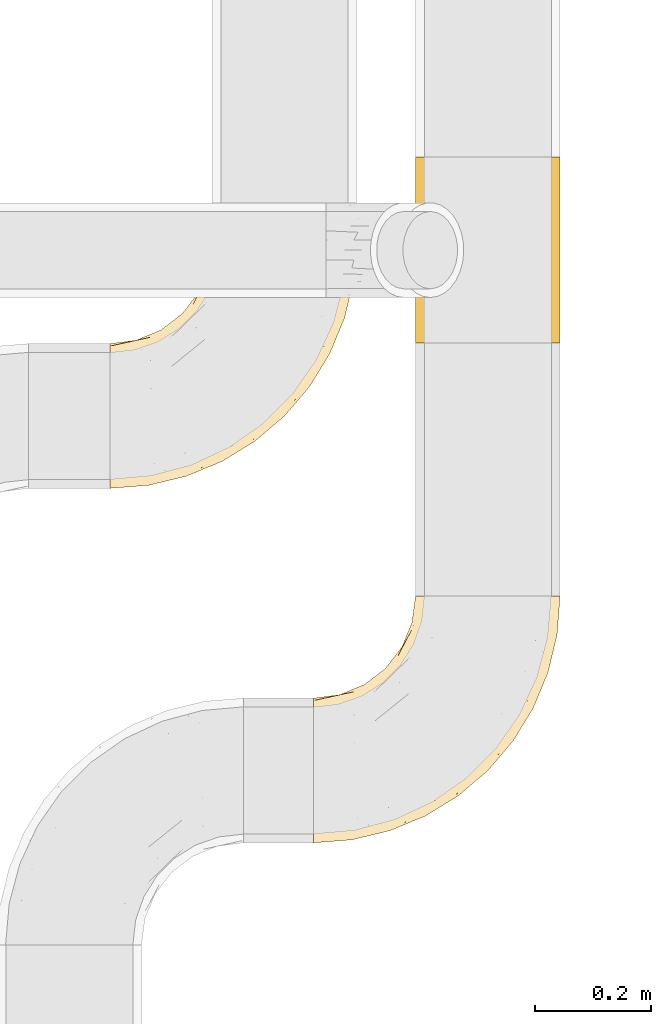
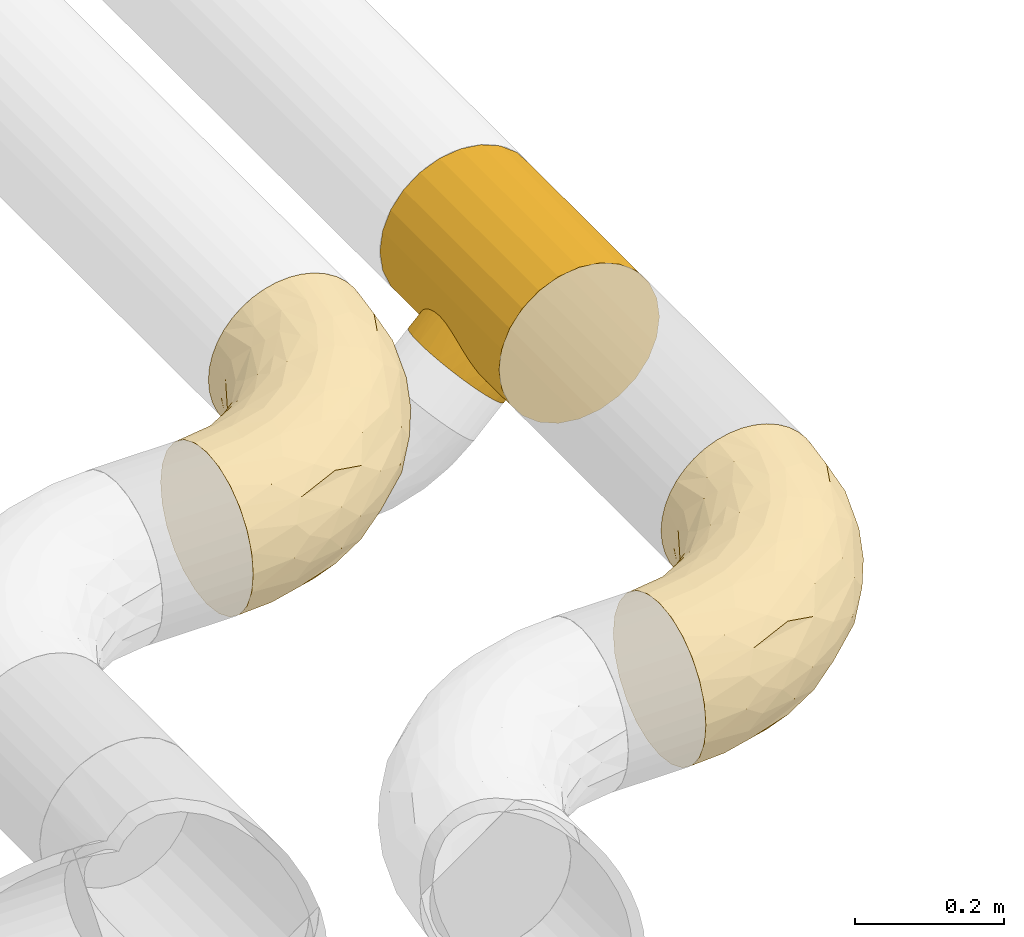
# One storey, part 39 of 93: 3 coverings.
"""IFC2X3 building model written with IfcOpenShell, lengths in millimetres."""

from ifc_helpers import new_model, entity, si_unit, converted_unit, derived_unit, direction, frame, origin, place, context, subcontext, project, spatial, faceted_brep, element, save


model = new_model("IFC2X3")

# Units and contexts
model_context = context("Model", 3, precision=0.01, world=origin(), true_north=direction((6.12303176911189e-17, 1.0)))
body_context = subcontext(model_context, "Body", "Model", "MODEL_VIEW")
ifc_project = project(units=[si_unit("LENGTHUNIT", "METRE", prefix="MILLI"), si_unit("AREAUNIT", "SQUARE_METRE"), si_unit("VOLUMEUNIT", "CUBIC_METRE"), converted_unit("PLANEANGLEUNIT", "DEGREE", entity("IfcRatioMeasure", 0.0174532925199433), si_unit("PLANEANGLEUNIT", "RADIAN"), dimensions=[0, 0, 0, 0, 0, 0, 0]), si_unit("MASSUNIT", "GRAM", prefix="KILO"), derived_unit("MASSDENSITYUNIT", [(si_unit("MASSUNIT", "GRAM", prefix="KILO"), 1), (si_unit("LENGTHUNIT", "METRE"), -3)]), derived_unit("MOMENTOFINERTIAUNIT", [(si_unit("LENGTHUNIT", "METRE"), 4)]), si_unit("TIMEUNIT", "SECOND"), si_unit("FREQUENCYUNIT", "HERTZ"), si_unit("THERMODYNAMICTEMPERATUREUNIT", "DEGREE_CELSIUS"), derived_unit("THERMALTRANSMITTANCEUNIT", [(si_unit("MASSUNIT", "GRAM", prefix="KILO"), 1), (si_unit("THERMODYNAMICTEMPERATUREUNIT", "KELVIN"), -1), (si_unit("TIMEUNIT", "SECOND"), -3)]), derived_unit("VOLUMETRICFLOWRATEUNIT", [(si_unit("LENGTHUNIT", "METRE"), 3), (si_unit("TIMEUNIT", "SECOND"), -1)]), derived_unit("MASSFLOWRATEUNIT", [(si_unit("MASSUNIT", "GRAM", prefix="KILO"), 1), (si_unit("TIMEUNIT", "SECOND"), -1)]), derived_unit("ROTATIONALFREQUENCYUNIT", [(si_unit("TIMEUNIT", "SECOND"), -1)]), si_unit("ELECTRICCURRENTUNIT", "AMPERE"), si_unit("ELECTRICVOLTAGEUNIT", "VOLT"), si_unit("POWERUNIT", "WATT"), si_unit("FORCEUNIT", "NEWTON", prefix="KILO"), si_unit("ILLUMINANCEUNIT", "LUX"), si_unit("LUMINOUSFLUXUNIT", "LUMEN"), si_unit("LUMINOUSINTENSITYUNIT", "CANDELA"), derived_unit("USERDEFINED", [(si_unit("MASSUNIT", "GRAM", prefix="KILO"), -1), (si_unit("LENGTHUNIT", "METRE"), -2), (si_unit("TIMEUNIT", "SECOND"), 3), (si_unit("LUMINOUSFLUXUNIT", "LUMEN"), 1)]), derived_unit("LINEARVELOCITYUNIT", [(si_unit("LENGTHUNIT", "METRE"), 1), (si_unit("TIMEUNIT", "SECOND"), -1)]), si_unit("PRESSUREUNIT", "PASCAL"), derived_unit("USERDEFINED", [(si_unit("LENGTHUNIT", "METRE"), -2), (si_unit("MASSUNIT", "GRAM", prefix="KILO"), 1), (si_unit("TIMEUNIT", "SECOND"), -2)]), derived_unit("LINEARFORCEUNIT", [(si_unit("MASSUNIT", "GRAM", prefix="KILO"), 1), (si_unit("LENGTHUNIT", "METRE"), 1), (si_unit("TIMEUNIT", "SECOND"), -2), (si_unit("LENGTHUNIT", "METRE"), -1)]), derived_unit("PLANARFORCEUNIT", [(si_unit("MASSUNIT", "GRAM", prefix="KILO"), 1), (si_unit("LENGTHUNIT", "METRE"), 1), (si_unit("TIMEUNIT", "SECOND"), -2), (si_unit("LENGTHUNIT", "METRE"), -2)])], contexts=[model_context])

# Site, building, storey
site_placement = place(None, origin())
site = spatial("IfcSite", under=ifc_project, at=site_placement, CompositionType="ELEMENT")
building_placement = place(site_placement, origin())
building = spatial("IfcBuilding", under=site, at=building_placement, CompositionType="ELEMENT")
storey_placement = place(building_placement, frame((0.0, 0.0, -4200.0)))
storey = spatial("IfcBuildingStorey", under=building, at=storey_placement, CompositionType="ELEMENT", Elevation=-4200.0)

# Coverings
covering_1_placement = place(storey_placement, frame((31128.4, 8452.66, 2673.9)))
element("IfcCovering", 1, at=covering_1_placement, inside=storey, Name=":ADSK_", ObjectType=":ADSK_", PredefinedType="INSULATION", context=body_context, shape_type="Brep", body=[
    faceted_brep([(282.13, 426.1, 249.06), (301.6, 426.1, 250.6), (321.07, 426.1, 249.06), (340.07, 426.1, 244.5), (358.12, 426.1, 237.02), (374.78, 426.1, 226.82), (389.63, 426.1, 214.13), (402.32, 426.1, 199.27), (412.53, 426.1, 182.61), (420.0, 426.1, 164.56), (424.56, 426.1, 145.56), (426.1, 426.1, 126.1), (424.56, 426.1, 106.62), (420.0, 426.1, 87.62), (412.52, 426.1, 69.57), (402.32, 426.1, 52.91), (389.63, 426.1, 38.06), (374.77, 426.1, 25.37), (358.11, 426.1, 15.16), (340.06, 426.1, 7.69), (321.06, 426.1, 3.13), (301.6, 426.1, 1.6), (282.12, 426.1, 3.13), (263.12, 426.1, 7.69), (245.07, 426.1, 15.17), (228.41, 426.1, 25.37), (213.56, 426.1, 38.06), (200.87, 426.1, 52.92), (190.66, 426.1, 69.58), (183.19, 426.1, 87.63), (178.63, 426.1, 106.63), (177.1, 426.1, 126.1), (178.63, 426.1, 145.57), (183.19, 426.1, 164.57), (190.67, 426.1, 182.62), (200.87, 426.1, 199.28), (213.56, 426.1, 214.13), (228.42, 426.1, 226.82), (245.08, 426.1, 237.03), (263.13, 426.1, 244.5), (1.6, 214.13, 38.06), (1.6, 188.35, 18.28), (1.6, 158.32, 5.84), (1.6, 126.1, 1.6), (1.6, 93.87, 5.84), (1.6, 63.85, 18.28), (1.6, 38.06, 38.06), (1.6, 18.28, 63.85), (1.6, 5.84, 93.87), (1.6, 1.6, 126.1), (1.6, 5.84, 158.32), (1.6, 18.28, 188.35), (1.6, 38.06, 214.13), (1.6, 63.85, 233.92), (1.6, 93.87, 246.35), (1.6, 126.1, 250.6), (1.6, 158.32, 246.35), (1.6, 188.35, 233.92), (1.6, 214.13, 214.13), (1.6, 233.92, 188.35), (1.6, 246.35, 158.32), (1.6, 250.6, 126.1), (1.6, 246.35, 93.87), (1.6, 233.92, 63.85), (68.0, 6.82, 126.1), (159.76, 37.17, 159.79), (77.64, 17.24, 171.65), (97.22, 14.57, 148.37), (405.8, 327.19, 170.98), (392.04, 266.32, 151.53), (414.51, 336.7, 148.43), (132.77, 22.37, 126.1), (194.31, 47.86, 126.1), (405.32, 294.92, 126.1), (379.83, 233.38, 126.1), (320.36, 154.69, 163.78), (248.34, 85.81, 158.07), (301.76, 125.93, 126.1), (366.71, 300.91, 216.14), (325.62, 252.35, 230.6), (335.07, 229.77, 215.18), (94.41, 82.86, 237.51), (134.75, 68.32, 220.0), (179.18, 125.85, 240.62), (251.11, 82.67, 126.1), (211.76, 75.22, 186.25), (345.02, 176.58, 126.1), (342.12, 329.96, 238.35), (59.52, 52.19, 222.84), (211.65, 174.79, 247.51), (297.5, 252.75, 242.96), (276.6, 259.55, 248.72), (110.66, 117.26, 247.51), (95.34, 36.0, 198.61), (253.95, 178.0, 238.33), (116.4, 148.93, 250.6), (168.27, 176.65, 250.6), (369.41, 245.67, 185.0), (213.73, 213.96, 250.6), (306.0, 162.34, 196.36), (391.55, 352.45, 204.33), (420.87, 359.69, 126.1), (295.83, 367.57, 250.6), (308.28, 319.13, 248.1), (251.04, 259.42, 250.6), (278.76, 311.29, 250.6), (60.12, 131.86, 250.6), (234.78, 111.84, 210.72), (221.69, 127.68, 228.5), (163.96, 62.63, 202.78), (288.95, 180.25, 223.0), (111.98, 283.07, 161.59), (89.35, 274.11, 126.1), (71.87, 261.78, 154.22), (64.74, 168.98, 245.5), (215.82, 340.36, 229.55), (222.14, 380.61, 225.61), (201.51, 353.11, 214.98), (126.52, 261.04, 208.87), (172.37, 285.47, 222.51), (163.8, 306.07, 202.61), (234.78, 334.75, 240.31), (167.67, 336.17, 182.2), (173.96, 374.65, 158.82), (143.34, 316.38, 156.41), (121.95, 181.78, 247.49), (258.85, 371.73, 244.95), (143.25, 244.15, 229.45), (169.65, 216.03, 246.68), (51.0, 200.06, 229.97), (47.02, 256.58, 126.1), (45.74, 245.7, 175.48), (93.2, 260.83, 182.39), (171.12, 380.67, 126.1), (153.58, 338.35, 126.1), (136.31, 292.7, 183.62), (125.69, 302.0, 126.1), (205.48, 264.25, 244.1), (249.33, 302.28, 248.44), (66.24, 229.31, 209.02), (204.54, 297.75, 235.25), (177.77, 262.06, 235.58), (185.41, 379.14, 183.86), (107.5, 210.47, 235.31), (169.66, 216.03, 5.51), (143.22, 244.14, 22.75), (177.76, 262.04, 16.61), (111.98, 283.07, 90.61), (93.2, 260.83, 69.8), (71.87, 261.78, 97.97), (222.13, 380.61, 26.59), (116.4, 148.93, 1.6), (121.95, 181.78, 4.7), (168.27, 176.65, 1.6), (143.34, 316.38, 95.79), (215.81, 340.36, 22.64), (234.77, 334.74, 11.89), (136.3, 292.7, 68.58), (173.96, 374.65, 93.38), (64.74, 168.98, 6.69), (60.12, 131.86, 1.6), (213.73, 213.96, 1.6), (205.49, 264.24, 8.09), (204.53, 297.74, 16.94), (126.53, 261.06, 43.34), (51.0, 200.06, 22.22), (66.24, 229.31, 43.17), (167.66, 336.17, 70.0), (278.76, 311.29, 1.6), (258.84, 371.72, 7.24), (295.83, 367.57, 1.6), (45.74, 245.7, 76.71), (185.4, 379.14, 68.34), (107.5, 210.47, 16.88), (201.5, 353.11, 37.22), (172.36, 285.46, 29.69), (163.8, 306.07, 49.59), (249.33, 302.29, 3.75), (251.04, 259.42, 1.6), (110.66, 117.26, 4.68), (288.95, 180.25, 29.2), (325.63, 252.36, 21.6), (335.08, 229.77, 37.02), (211.65, 174.79, 4.68), (369.41, 245.69, 67.18), (405.8, 327.2, 81.2), (392.04, 266.32, 100.65), (342.12, 329.97, 13.83), (94.41, 82.86, 14.68), (59.51, 52.19, 29.35), (95.34, 36.0, 53.58), (297.5, 252.75, 9.24), (276.6, 259.54, 3.47), (179.18, 125.85, 11.57), (159.76, 37.17, 92.4), (77.64, 17.24, 80.54), (391.55, 352.45, 47.86), (134.74, 68.32, 32.19), (320.36, 154.69, 88.4), (306.02, 162.36, 55.83), (97.22, 14.57, 103.83), (248.34, 85.81, 94.12), (211.76, 75.22, 65.94), (234.79, 111.84, 41.48), (414.51, 336.71, 103.76), (308.29, 319.13, 4.09), (253.95, 178.0, 13.86), (221.69, 127.67, 23.69), (366.7, 300.91, 36.04), (163.97, 62.64, 49.41)], [[[0, 1, 2, 3, 4, 5, 6, 7, 8, 9, 10, 11, 12, 13, 14, 15, 16, 17, 18, 19, 20, 21, 22, 23, 24, 25, 26, 27, 28, 29, 30, 31, 32, 33, 34, 35, 36, 37, 38, 39]], [[40, 41, 42, 43, 44, 45, 46, 47, 48, 49, 50, 51, 52, 53, 54, 55, 56, 57, 58, 59, 60, 61, 62, 63]], [[49, 64, 50]], [[65, 66, 67]], [[68, 69, 70]], [[65, 71, 72]], [[71, 65, 67]], [[73, 69, 74]], [[75, 76, 77]], [[78, 79, 80]], [[65, 72, 76]], [[51, 50, 66]], [[81, 82, 83]], [[84, 76, 72]], [[76, 85, 65]], [[74, 69, 86]], [[5, 87, 78]], [[52, 88, 53]], [[89, 90, 91]], [[55, 54, 92]], [[82, 88, 93]], [[94, 89, 83]], [[87, 90, 79]], [[95, 89, 96]], [[5, 4, 87]], [[83, 89, 92]], [[90, 89, 94]], [[78, 80, 97]], [[65, 85, 93]], [[95, 92, 89]], [[96, 89, 98]], [[99, 75, 97]], [[3, 87, 4]], [[90, 94, 79]], [[8, 68, 9]], [[75, 77, 86]], [[100, 7, 6]], [[83, 92, 81]], [[70, 10, 9]], [[101, 70, 73]], [[54, 81, 92]], [[68, 70, 9]], [[97, 100, 78]], [[7, 100, 8]], [[8, 100, 68]], [[101, 11, 10]], [[2, 102, 103]], [[100, 6, 5]], [[104, 91, 105]], [[102, 105, 103]], [[92, 95, 106]], [[1, 102, 2]], [[81, 54, 53]], [[107, 108, 82]], [[68, 97, 69]], [[2, 103, 3]], [[98, 89, 91]], [[90, 103, 91]], [[90, 87, 103]], [[107, 85, 99]], [[103, 87, 3]], [[100, 97, 68]], [[100, 5, 78]], [[93, 52, 51]], [[75, 69, 97]], [[75, 86, 69]], [[88, 81, 53]], [[55, 92, 106]], [[93, 51, 66]], [[109, 82, 93]], [[108, 94, 83]], [[79, 94, 110]], [[107, 99, 110]], [[85, 75, 99]], [[77, 76, 84]], [[75, 85, 76]], [[110, 94, 108]], [[109, 107, 82]], [[82, 108, 83]], [[110, 108, 107]], [[67, 50, 64]], [[93, 66, 65]], [[80, 79, 110]], [[78, 87, 79]], [[110, 99, 80]], [[97, 80, 99]], [[73, 70, 69]], [[10, 70, 101]], [[50, 67, 66]], [[71, 67, 64]], [[105, 91, 103]], [[91, 104, 98]], [[93, 88, 52]], [[81, 88, 82]], [[93, 85, 109]], [[107, 109, 85]], [[111, 112, 113]], [[56, 55, 106]], [[106, 114, 56]], [[115, 116, 117]], [[118, 119, 120]], [[116, 115, 121]], [[95, 114, 106]], [[122, 123, 124]], [[95, 125, 114]], [[102, 39, 126]], [[119, 118, 127]], [[96, 98, 128]], [[114, 57, 56]], [[57, 129, 58]], [[36, 35, 116]], [[61, 60, 130]], [[113, 131, 132]], [[32, 133, 123]], [[134, 123, 133]], [[113, 112, 130]], [[126, 116, 121]], [[131, 113, 60]], [[124, 111, 135]], [[122, 124, 135]], [[111, 136, 112]], [[128, 98, 137]], [[137, 104, 138]], [[132, 135, 111]], [[126, 105, 102]], [[60, 113, 130]], [[127, 118, 139]], [[126, 39, 38]], [[140, 121, 115]], [[1, 0, 102]], [[126, 121, 138]], [[38, 37, 116]], [[129, 139, 58]], [[0, 39, 102]], [[127, 141, 119]], [[116, 126, 38]], [[142, 34, 33]], [[142, 123, 122]], [[137, 98, 104]], [[31, 133, 32]], [[139, 132, 131]], [[123, 134, 124]], [[35, 34, 142]], [[35, 117, 116]], [[124, 134, 136]], [[117, 122, 120]], [[33, 32, 123]], [[33, 123, 142]], [[37, 36, 116]], [[58, 139, 59]], [[129, 114, 143]], [[105, 138, 104]], [[125, 128, 143]], [[125, 95, 96]], [[118, 135, 132]], [[120, 122, 135]], [[132, 139, 118]], [[127, 139, 143]], [[114, 129, 57]], [[139, 129, 143]], [[60, 59, 131]], [[139, 131, 59]], [[128, 125, 96]], [[143, 114, 125]], [[118, 120, 135]], [[117, 120, 119]], [[143, 128, 127]], [[141, 128, 137]], [[136, 111, 124]], [[132, 111, 113]], [[122, 117, 142]], [[35, 142, 117]], [[117, 119, 115]], [[119, 141, 140]], [[126, 138, 105]], [[137, 138, 121]], [[128, 141, 127]], [[140, 141, 137]], [[121, 140, 137]], [[119, 140, 115]], [[144, 145, 146]], [[147, 148, 149]], [[62, 61, 130]], [[149, 62, 130]], [[26, 150, 27]], [[151, 152, 153]], [[134, 154, 136]], [[155, 150, 156]], [[130, 112, 149]], [[157, 147, 154]], [[152, 144, 153]], [[154, 134, 158]], [[42, 159, 160]], [[161, 153, 144]], [[162, 146, 163]], [[160, 43, 42]], [[41, 159, 42]], [[164, 148, 157]], [[41, 40, 165]], [[40, 63, 166]], [[158, 167, 154]], [[151, 160, 159]], [[168, 169, 170]], [[63, 171, 166]], [[23, 170, 169]], [[152, 151, 159]], [[29, 172, 158]], [[173, 166, 145]], [[133, 31, 30]], [[149, 148, 171]], [[144, 162, 161]], [[172, 29, 28]], [[174, 172, 27]], [[149, 171, 62]], [[174, 27, 150]], [[158, 134, 133]], [[155, 174, 150]], [[167, 158, 172]], [[174, 175, 176]], [[162, 156, 177]], [[169, 168, 177]], [[162, 178, 161]], [[26, 25, 150]], [[166, 164, 145]], [[23, 169, 24]], [[169, 150, 24]], [[169, 156, 150]], [[136, 154, 147]], [[22, 21, 170]], [[133, 30, 158]], [[150, 25, 24]], [[23, 22, 170]], [[157, 154, 167]], [[178, 177, 168]], [[112, 136, 147]], [[29, 158, 30]], [[165, 159, 41]], [[165, 166, 173]], [[167, 176, 157]], [[157, 176, 164]], [[164, 175, 145]], [[166, 148, 164]], [[166, 165, 40]], [[159, 165, 173]], [[166, 171, 148]], [[63, 62, 171]], [[159, 173, 152]], [[144, 152, 173]], [[174, 176, 167]], [[164, 176, 175]], [[146, 145, 175]], [[144, 173, 145]], [[148, 147, 157]], [[147, 149, 112]], [[27, 172, 28]], [[174, 167, 172]], [[163, 156, 162]], [[175, 174, 155]], [[162, 177, 178]], [[169, 177, 156]], [[163, 175, 155]], [[144, 146, 162]], [[175, 163, 146]], [[156, 163, 155]], [[160, 179, 43]], [[180, 181, 182]], [[151, 153, 183]], [[184, 185, 186]], [[183, 179, 151]], [[186, 74, 86]], [[153, 161, 183]], [[187, 19, 18]], [[188, 44, 179]], [[46, 189, 190]], [[181, 191, 187]], [[183, 161, 192]], [[186, 73, 74]], [[193, 179, 183]], [[194, 195, 190]], [[184, 196, 185]], [[64, 49, 48]], [[44, 188, 45]], [[193, 188, 179]], [[189, 188, 197]], [[14, 13, 185]], [[198, 199, 184]], [[195, 200, 48]], [[201, 194, 202]], [[182, 184, 199]], [[201, 77, 84]], [[199, 203, 180]], [[194, 201, 72]], [[45, 189, 46]], [[13, 12, 204]], [[205, 192, 168]], [[14, 196, 15]], [[170, 21, 20]], [[186, 86, 198]], [[187, 205, 19]], [[19, 205, 20]], [[20, 205, 170]], [[151, 179, 160]], [[205, 191, 192]], [[193, 206, 207]], [[208, 17, 196]], [[193, 197, 188]], [[43, 179, 44]], [[187, 17, 208]], [[46, 190, 47]], [[84, 72, 201]], [[198, 184, 186]], [[86, 77, 198]], [[194, 72, 71]], [[186, 204, 73]], [[204, 186, 185]], [[15, 196, 16]], [[184, 208, 196]], [[192, 161, 178]], [[12, 11, 101]], [[17, 187, 18]], [[47, 195, 48]], [[12, 101, 204]], [[181, 180, 206]], [[17, 16, 196]], [[14, 185, 196]], [[168, 170, 205]], [[206, 183, 191]], [[183, 206, 193]], [[187, 191, 205]], [[200, 71, 64]], [[197, 209, 190]], [[194, 190, 202]], [[181, 206, 191]], [[207, 180, 203]], [[198, 202, 199]], [[203, 199, 202]], [[202, 198, 201]], [[77, 201, 198]], [[209, 203, 202]], [[207, 197, 193]], [[180, 207, 206]], [[197, 207, 203]], [[190, 195, 47]], [[200, 195, 194]], [[187, 208, 181]], [[182, 181, 208]], [[184, 182, 208]], [[199, 180, 182]], [[204, 185, 13]], [[73, 204, 101]], [[71, 200, 194]], [[48, 200, 64]], [[183, 192, 191]], [[168, 192, 178]], [[188, 189, 45]], [[190, 189, 197]], [[203, 209, 197]], [[202, 190, 209]]]),
])
covering_2_placement = place(storey_placement, frame((31271.78, 9314.14, 2641.78)))
element("IfcCovering", 2, at=covering_2_placement, inside=storey, Name=":ADSK_", ObjectType=":ADSK_", PredefinedType="INSULATION", context=body_context, shape_type="Brep", body=[
    faceted_brep([(278.48, 0.0, 190.44), (266.04, 0.0, 220.47), (246.25, 0.0, 246.25), (220.47, 0.0, 266.04), (190.44, 0.0, 278.48), (158.22, 0.0, 282.72), (126.0, 0.0, 278.48), (95.97, 0.0, 266.04), (70.18, 0.0, 246.25), (50.4, 0.0, 220.47), (37.96, 0.0, 190.44), (33.72, 0.0, 158.22), (37.96, 0.0, 126.0), (44.18, 0.0, 110.98), (50.4, 0.0, 95.97), (60.29, 0.0, 83.08), (70.18, 0.0, 70.18), (83.08, 0.0, 60.29), (95.97, 0.0, 50.4), (110.98, 0.0, 44.18), (126.0, 0.0, 37.96), (158.22, 0.0, 33.72), (190.44, 0.0, 37.96), (220.47, 0.0, 50.4), (246.25, 0.0, 70.18), (266.04, 0.0, 95.97), (278.48, 0.0, 126.0), (282.72, 0.0, 158.22), (70.18, 320.0, 246.25), (95.97, 320.0, 266.04), (126.0, 320.0, 278.48), (158.22, 320.0, 282.72), (190.44, 320.0, 278.48), (220.47, 320.0, 266.04), (246.25, 320.0, 246.25), (266.04, 320.0, 220.47), (278.48, 320.0, 190.44), (282.72, 320.0, 158.22), (278.48, 320.0, 126.0), (266.04, 320.0, 95.97), (246.25, 320.0, 70.18), (220.47, 320.0, 50.4), (190.44, 320.0, 37.96), (158.22, 320.0, 33.72), (126.0, 320.0, 37.96), (110.98, 320.0, 44.18), (95.97, 320.0, 50.4), (83.08, 320.0, 60.29), (70.18, 320.0, 70.18), (60.29, 320.0, 83.08), (50.4, 320.0, 95.97), (44.18, 320.0, 110.98), (37.96, 320.0, 126.0), (33.72, 320.0, 158.22), (37.96, 320.0, 190.44), (50.4, 320.0, 220.47), (34.04, 160.0, 149.3), (52.34, 236.33, 92.72), (60.47, 240.18, 81.11), (37.9, 212.37, 126.21), (35.83, 201.08, 135.38), (45.93, 89.78, 104.44), (34.69, 188.41, 142.72), (34.18, 174.57, 147.58), (34.18, 145.43, 147.58), (60.47, 79.82, 81.11), (34.69, 131.59, 142.72), (35.83, 118.92, 135.38), (41.19, 222.15, 115.75), (45.93, 230.22, 104.44), (70.18, 241.5, 70.18), (70.18, 78.5, 70.18), (37.9, 107.63, 126.21), (41.19, 97.85, 115.75), (52.34, 83.67, 92.72), (81.11, 240.18, 60.47), (81.11, 79.82, 60.47), (92.72, 236.33, 52.34), (115.75, 222.15, 41.19), (104.44, 230.22, 45.93), (92.72, 83.67, 52.34), (115.75, 97.85, 41.19), (104.44, 89.78, 45.93), (126.21, 107.63, 37.9), (126.21, 212.37, 37.9), (135.38, 201.08, 35.83), (147.58, 174.57, 34.18), (142.72, 188.41, 34.69), (149.3, 160.0, 34.04), (142.72, 131.59, 34.69), (147.58, 145.43, 34.18), (135.38, 118.92, 35.83), (1.6, 160.0, 116.85), (3.56, 181.09, 114.89), (9.32, 200.75, 109.13), (18.47, 217.63, 99.97), (30.41, 230.58, 88.04), (44.31, 238.72, 74.14), (59.22, 241.5, 59.22), (74.14, 238.72, 44.31), (88.04, 230.58, 30.41), (99.97, 217.63, 18.47), (109.13, 200.75, 9.32), (114.89, 181.09, 3.56), (116.85, 160.0, 1.6), (114.89, 138.91, 3.56), (109.13, 119.25, 9.32), (99.97, 102.37, 18.47), (88.04, 89.42, 30.41), (74.14, 81.28, 44.31), (59.22, 78.5, 59.22), (44.31, 81.28, 74.14), (30.41, 89.42, 88.04), (18.47, 102.37, 99.97), (9.32, 119.25, 109.13), (3.56, 138.91, 114.89)], [[[0, 1, 2, 3, 4, 5, 6, 7, 8, 9, 10, 11, 12, 13, 14, 15, 16, 17, 18, 19, 20, 21, 22, 23, 24, 25, 26, 27]], [[28, 29, 30, 31, 32, 33, 34, 35, 36, 37, 38, 39, 40, 41, 42, 43, 44, 45, 46, 47, 48, 49, 50, 51, 52, 53, 54, 55]], [[3, 33, 32, 4]], [[4, 32, 31, 5]], [[34, 33, 3, 2]], [[6, 30, 29, 7]], [[7, 29, 28, 8]], [[5, 31, 30, 6]], [[54, 10, 9, 55]], [[55, 9, 8, 28]], [[56, 54, 53]], [[57, 49, 58]], [[52, 59, 60]], [[61, 14, 13]], [[62, 63, 53]], [[60, 62, 53]], [[60, 53, 52]], [[53, 63, 56]], [[56, 11, 10]], [[56, 64, 11]], [[65, 16, 15]], [[66, 67, 11]], [[68, 51, 69]], [[64, 66, 11]], [[56, 10, 54]], [[11, 67, 12]], [[51, 50, 69]], [[68, 52, 51]], [[50, 57, 69]], [[48, 70, 58]], [[16, 65, 71]], [[50, 49, 57]], [[58, 49, 48]], [[72, 73, 12]], [[73, 13, 12]], [[13, 73, 61]], [[72, 12, 67]], [[65, 15, 74]], [[15, 14, 74]], [[74, 14, 61]], [[68, 59, 52]], [[70, 48, 75]], [[16, 71, 76]], [[77, 75, 47]], [[47, 46, 77]], [[44, 78, 45]], [[79, 45, 78]], [[46, 79, 77]], [[16, 76, 17]], [[80, 18, 17]], [[81, 20, 19]], [[19, 18, 82]], [[20, 81, 83]], [[82, 18, 80]], [[84, 78, 44]], [[84, 44, 85]], [[86, 87, 43]], [[85, 43, 87]], [[75, 48, 47]], [[42, 41, 23, 22]], [[88, 43, 42]], [[86, 43, 88]], [[44, 43, 85]], [[23, 41, 40, 24]], [[89, 90, 21]], [[80, 17, 76]], [[91, 21, 20]], [[79, 46, 45]], [[89, 21, 91]], [[88, 21, 90]], [[21, 88, 22]], [[42, 22, 88]], [[81, 19, 82]], [[91, 20, 83]], [[25, 39, 38, 26]], [[26, 38, 37, 27]], [[40, 39, 25, 24]], [[0, 36, 35, 1]], [[1, 35, 34, 2]], [[27, 37, 36, 0]], [[92, 93, 94, 95, 96, 97, 98, 99, 100, 101, 102, 103, 104, 105, 106, 107, 108, 109, 110, 111, 112, 113, 114, 115]], [[58, 70, 98]], [[58, 98, 97]], [[57, 97, 96]], [[57, 58, 97]], [[68, 69, 96]], [[57, 96, 69]], [[96, 95, 68]], [[59, 95, 94]], [[94, 93, 62]], [[92, 63, 93]], [[59, 94, 60]], [[93, 63, 62]], [[62, 60, 94]], [[63, 92, 56]], [[95, 59, 68]], [[64, 92, 115]], [[115, 114, 66]], [[72, 114, 113]], [[72, 67, 114]], [[56, 92, 64]], [[64, 115, 66]], [[114, 67, 66]], [[73, 113, 112]], [[111, 110, 65]], [[74, 112, 111]], [[61, 73, 112]], [[65, 74, 111]], [[71, 65, 110]], [[61, 112, 74]], [[113, 73, 72]], [[76, 71, 110]], [[76, 110, 109]], [[80, 109, 108]], [[80, 76, 109]], [[81, 82, 108]], [[80, 108, 82]], [[108, 107, 81]], [[83, 107, 106]], [[106, 105, 89]], [[104, 90, 105]], [[83, 106, 91]], [[105, 90, 89]], [[89, 91, 106]], [[90, 104, 88]], [[107, 83, 81]], [[86, 104, 103]], [[103, 102, 87]], [[84, 102, 101]], [[84, 85, 102]], [[88, 104, 86]], [[86, 103, 87]], [[102, 85, 87]], [[78, 101, 100]], [[100, 99, 77]], [[98, 75, 99]], [[79, 78, 100]], [[75, 77, 99]], [[70, 75, 98]], [[79, 100, 77]], [[101, 78, 84]]]),
])
covering_3_placement = place(storey_placement, frame((30778.4, 9062.66, 2673.9)))
element("IfcCovering", 3, at=covering_3_placement, inside=storey, Name=":ADSK_", ObjectType=":ADSK_", PredefinedType="INSULATION", context=body_context, shape_type="Brep", body=[
    faceted_brep([(282.13, 426.1, 249.06), (301.6, 426.1, 250.6), (321.07, 426.1, 249.06), (340.07, 426.1, 244.5), (358.12, 426.1, 237.02), (374.78, 426.1, 226.82), (389.63, 426.1, 214.13), (402.32, 426.1, 199.27), (412.53, 426.1, 182.61), (420.0, 426.1, 164.56), (424.56, 426.1, 145.56), (426.1, 426.1, 126.1), (424.56, 426.1, 106.62), (420.0, 426.1, 87.62), (412.52, 426.1, 69.57), (402.32, 426.1, 52.91), (389.63, 426.1, 38.06), (374.77, 426.1, 25.37), (358.11, 426.1, 15.16), (340.06, 426.1, 7.69), (321.06, 426.1, 3.13), (301.6, 426.1, 1.6), (282.12, 426.1, 3.13), (263.12, 426.1, 7.69), (245.07, 426.1, 15.17), (228.41, 426.1, 25.37), (213.56, 426.1, 38.06), (200.87, 426.1, 52.92), (190.66, 426.1, 69.58), (183.19, 426.1, 87.63), (178.63, 426.1, 106.63), (177.1, 426.1, 126.1), (178.63, 426.1, 145.57), (183.19, 426.1, 164.57), (190.67, 426.1, 182.62), (200.87, 426.1, 199.28), (213.56, 426.1, 214.13), (228.42, 426.1, 226.82), (245.08, 426.1, 237.03), (263.13, 426.1, 244.5), (1.6, 214.13, 38.06), (1.6, 188.35, 18.28), (1.6, 158.32, 5.84), (1.6, 126.1, 1.6), (1.6, 93.87, 5.84), (1.6, 63.85, 18.28), (1.6, 38.06, 38.06), (1.6, 18.28, 63.85), (1.6, 5.84, 93.87), (1.6, 1.6, 126.1), (1.6, 5.84, 158.32), (1.6, 18.28, 188.35), (1.6, 38.06, 214.13), (1.6, 63.85, 233.92), (1.6, 93.87, 246.35), (1.6, 126.1, 250.6), (1.6, 158.32, 246.35), (1.6, 188.35, 233.92), (1.6, 214.13, 214.13), (1.6, 233.92, 188.35), (1.6, 246.35, 158.32), (1.6, 250.6, 126.1), (1.6, 246.35, 93.87), (1.6, 233.92, 63.85), (68.0, 6.82, 126.1), (159.76, 37.17, 159.79), (77.64, 17.24, 171.65), (97.22, 14.57, 148.37), (405.8, 327.19, 170.98), (392.04, 266.32, 151.53), (414.51, 336.7, 148.43), (132.77, 22.37, 126.1), (194.31, 47.86, 126.1), (405.32, 294.92, 126.1), (379.83, 233.38, 126.1), (320.36, 154.69, 163.78), (248.34, 85.81, 158.07), (301.76, 125.93, 126.1), (366.71, 300.91, 216.14), (325.62, 252.35, 230.6), (335.07, 229.77, 215.18), (94.41, 82.86, 237.51), (134.75, 68.32, 220.0), (179.18, 125.85, 240.62), (251.11, 82.67, 126.1), (211.76, 75.22, 186.25), (345.02, 176.58, 126.1), (342.12, 329.96, 238.35), (59.52, 52.19, 222.84), (211.65, 174.79, 247.51), (297.5, 252.75, 242.96), (276.6, 259.55, 248.72), (110.66, 117.26, 247.51), (95.34, 36.0, 198.61), (253.95, 178.0, 238.33), (116.4, 148.93, 250.6), (168.27, 176.65, 250.6), (369.41, 245.67, 185.0), (213.73, 213.96, 250.6), (306.0, 162.34, 196.36), (391.55, 352.45, 204.33), (420.87, 359.69, 126.1), (295.83, 367.57, 250.6), (308.28, 319.13, 248.1), (251.04, 259.42, 250.6), (278.76, 311.29, 250.6), (60.12, 131.86, 250.6), (234.78, 111.84, 210.72), (221.69, 127.68, 228.5), (163.96, 62.63, 202.78), (288.95, 180.25, 223.0), (111.98, 283.07, 161.59), (89.35, 274.11, 126.1), (71.87, 261.78, 154.22), (64.74, 168.98, 245.5), (215.82, 340.36, 229.55), (222.14, 380.61, 225.61), (201.51, 353.11, 214.98), (126.52, 261.04, 208.87), (172.37, 285.47, 222.51), (163.8, 306.07, 202.61), (234.78, 334.75, 240.31), (167.67, 336.17, 182.2), (173.96, 374.65, 158.82), (143.34, 316.38, 156.41), (121.95, 181.78, 247.49), (258.85, 371.73, 244.95), (143.25, 244.15, 229.45), (169.65, 216.03, 246.68), (51.0, 200.06, 229.97), (47.02, 256.58, 126.1), (45.74, 245.7, 175.48), (93.2, 260.83, 182.39), (171.12, 380.67, 126.1), (153.58, 338.35, 126.1), (136.31, 292.7, 183.62), (125.69, 302.0, 126.1), (205.48, 264.25, 244.1), (249.33, 302.28, 248.44), (66.24, 229.31, 209.02), (204.54, 297.75, 235.25), (177.77, 262.06, 235.58), (185.41, 379.14, 183.86), (107.5, 210.47, 235.31), (169.66, 216.03, 5.51), (143.22, 244.14, 22.75), (177.76, 262.04, 16.61), (111.98, 283.07, 90.61), (93.2, 260.83, 69.8), (71.87, 261.78, 97.97), (222.13, 380.61, 26.59), (116.4, 148.93, 1.6), (121.95, 181.78, 4.7), (168.27, 176.65, 1.6), (143.34, 316.38, 95.79), (215.81, 340.36, 22.64), (234.77, 334.74, 11.89), (136.3, 292.7, 68.58), (173.96, 374.65, 93.38), (64.74, 168.98, 6.69), (60.12, 131.86, 1.6), (213.73, 213.96, 1.6), (205.49, 264.24, 8.09), (204.53, 297.74, 16.94), (126.53, 261.06, 43.34), (51.0, 200.06, 22.22), (66.24, 229.31, 43.17), (167.66, 336.17, 70.0), (278.76, 311.29, 1.6), (258.84, 371.72, 7.24), (295.83, 367.57, 1.6), (45.74, 245.7, 76.71), (185.4, 379.14, 68.34), (107.5, 210.47, 16.88), (201.5, 353.11, 37.22), (172.36, 285.46, 29.69), (163.8, 306.07, 49.59), (249.33, 302.29, 3.75), (251.04, 259.42, 1.6), (110.66, 117.26, 4.68), (288.95, 180.25, 29.2), (325.63, 252.36, 21.6), (335.08, 229.77, 37.02), (211.65, 174.79, 4.68), (369.41, 245.69, 67.18), (405.8, 327.2, 81.2), (392.04, 266.32, 100.65), (342.12, 329.97, 13.83), (94.41, 82.86, 14.68), (59.51, 52.19, 29.35), (95.34, 36.0, 53.58), (297.5, 252.75, 9.24), (276.6, 259.54, 3.47), (179.18, 125.85, 11.57), (159.76, 37.17, 92.4), (77.64, 17.24, 80.54), (391.55, 352.45, 47.86), (134.74, 68.32, 32.19), (320.36, 154.69, 88.4), (306.02, 162.36, 55.83), (97.22, 14.57, 103.83), (248.34, 85.81, 94.12), (211.76, 75.22, 65.94), (234.79, 111.84, 41.48), (414.51, 336.71, 103.76), (308.29, 319.13, 4.09), (253.95, 178.0, 13.86), (221.69, 127.67, 23.69), (366.7, 300.91, 36.04), (163.97, 62.64, 49.41)], [[[0, 1, 2, 3, 4, 5, 6, 7, 8, 9, 10, 11, 12, 13, 14, 15, 16, 17, 18, 19, 20, 21, 22, 23, 24, 25, 26, 27, 28, 29, 30, 31, 32, 33, 34, 35, 36, 37, 38, 39]], [[40, 41, 42, 43, 44, 45, 46, 47, 48, 49, 50, 51, 52, 53, 54, 55, 56, 57, 58, 59, 60, 61, 62, 63]], [[49, 64, 50]], [[65, 66, 67]], [[68, 69, 70]], [[65, 71, 72]], [[71, 65, 67]], [[73, 69, 74]], [[75, 76, 77]], [[78, 79, 80]], [[65, 72, 76]], [[51, 50, 66]], [[81, 82, 83]], [[84, 76, 72]], [[76, 85, 65]], [[74, 69, 86]], [[5, 87, 78]], [[52, 88, 53]], [[89, 90, 91]], [[55, 54, 92]], [[82, 88, 93]], [[94, 89, 83]], [[87, 90, 79]], [[95, 89, 96]], [[5, 4, 87]], [[83, 89, 92]], [[90, 89, 94]], [[78, 80, 97]], [[65, 85, 93]], [[95, 92, 89]], [[96, 89, 98]], [[99, 75, 97]], [[3, 87, 4]], [[90, 94, 79]], [[8, 68, 9]], [[75, 77, 86]], [[100, 7, 6]], [[83, 92, 81]], [[70, 10, 9]], [[101, 70, 73]], [[54, 81, 92]], [[68, 70, 9]], [[97, 100, 78]], [[7, 100, 8]], [[8, 100, 68]], [[101, 11, 10]], [[2, 102, 103]], [[100, 6, 5]], [[104, 91, 105]], [[102, 105, 103]], [[92, 95, 106]], [[1, 102, 2]], [[81, 54, 53]], [[107, 108, 82]], [[68, 97, 69]], [[2, 103, 3]], [[98, 89, 91]], [[90, 103, 91]], [[90, 87, 103]], [[107, 85, 99]], [[103, 87, 3]], [[100, 97, 68]], [[100, 5, 78]], [[93, 52, 51]], [[75, 69, 97]], [[75, 86, 69]], [[88, 81, 53]], [[55, 92, 106]], [[93, 51, 66]], [[109, 82, 93]], [[108, 94, 83]], [[79, 94, 110]], [[107, 99, 110]], [[85, 75, 99]], [[77, 76, 84]], [[75, 85, 76]], [[110, 94, 108]], [[109, 107, 82]], [[82, 108, 83]], [[110, 108, 107]], [[67, 50, 64]], [[93, 66, 65]], [[80, 79, 110]], [[78, 87, 79]], [[110, 99, 80]], [[97, 80, 99]], [[73, 70, 69]], [[10, 70, 101]], [[50, 67, 66]], [[71, 67, 64]], [[105, 91, 103]], [[91, 104, 98]], [[93, 88, 52]], [[81, 88, 82]], [[93, 85, 109]], [[107, 109, 85]], [[111, 112, 113]], [[56, 55, 106]], [[106, 114, 56]], [[115, 116, 117]], [[118, 119, 120]], [[116, 115, 121]], [[95, 114, 106]], [[122, 123, 124]], [[95, 125, 114]], [[102, 39, 126]], [[119, 118, 127]], [[96, 98, 128]], [[114, 57, 56]], [[57, 129, 58]], [[36, 35, 116]], [[61, 60, 130]], [[113, 131, 132]], [[32, 133, 123]], [[134, 123, 133]], [[113, 112, 130]], [[126, 116, 121]], [[131, 113, 60]], [[124, 111, 135]], [[122, 124, 135]], [[111, 136, 112]], [[128, 98, 137]], [[137, 104, 138]], [[132, 135, 111]], [[126, 105, 102]], [[60, 113, 130]], [[127, 118, 139]], [[126, 39, 38]], [[140, 121, 115]], [[1, 0, 102]], [[126, 121, 138]], [[38, 37, 116]], [[129, 139, 58]], [[0, 39, 102]], [[127, 141, 119]], [[116, 126, 38]], [[142, 34, 33]], [[142, 123, 122]], [[137, 98, 104]], [[31, 133, 32]], [[139, 132, 131]], [[123, 134, 124]], [[35, 34, 142]], [[35, 117, 116]], [[124, 134, 136]], [[117, 122, 120]], [[33, 32, 123]], [[33, 123, 142]], [[37, 36, 116]], [[58, 139, 59]], [[129, 114, 143]], [[105, 138, 104]], [[125, 128, 143]], [[125, 95, 96]], [[118, 135, 132]], [[120, 122, 135]], [[132, 139, 118]], [[127, 139, 143]], [[114, 129, 57]], [[139, 129, 143]], [[60, 59, 131]], [[139, 131, 59]], [[128, 125, 96]], [[143, 114, 125]], [[118, 120, 135]], [[117, 120, 119]], [[143, 128, 127]], [[141, 128, 137]], [[136, 111, 124]], [[132, 111, 113]], [[122, 117, 142]], [[35, 142, 117]], [[117, 119, 115]], [[119, 141, 140]], [[126, 138, 105]], [[137, 138, 121]], [[128, 141, 127]], [[140, 141, 137]], [[121, 140, 137]], [[119, 140, 115]], [[144, 145, 146]], [[147, 148, 149]], [[62, 61, 130]], [[149, 62, 130]], [[26, 150, 27]], [[151, 152, 153]], [[134, 154, 136]], [[155, 150, 156]], [[130, 112, 149]], [[157, 147, 154]], [[152, 144, 153]], [[154, 134, 158]], [[42, 159, 160]], [[161, 153, 144]], [[162, 146, 163]], [[160, 43, 42]], [[41, 159, 42]], [[164, 148, 157]], [[41, 40, 165]], [[40, 63, 166]], [[158, 167, 154]], [[151, 160, 159]], [[168, 169, 170]], [[63, 171, 166]], [[23, 170, 169]], [[152, 151, 159]], [[29, 172, 158]], [[173, 166, 145]], [[133, 31, 30]], [[149, 148, 171]], [[144, 162, 161]], [[172, 29, 28]], [[174, 172, 27]], [[149, 171, 62]], [[174, 27, 150]], [[158, 134, 133]], [[155, 174, 150]], [[167, 158, 172]], [[174, 175, 176]], [[162, 156, 177]], [[169, 168, 177]], [[162, 178, 161]], [[26, 25, 150]], [[166, 164, 145]], [[23, 169, 24]], [[169, 150, 24]], [[169, 156, 150]], [[136, 154, 147]], [[22, 21, 170]], [[133, 30, 158]], [[150, 25, 24]], [[23, 22, 170]], [[157, 154, 167]], [[178, 177, 168]], [[112, 136, 147]], [[29, 158, 30]], [[165, 159, 41]], [[165, 166, 173]], [[167, 176, 157]], [[157, 176, 164]], [[164, 175, 145]], [[166, 148, 164]], [[166, 165, 40]], [[159, 165, 173]], [[166, 171, 148]], [[63, 62, 171]], [[159, 173, 152]], [[144, 152, 173]], [[174, 176, 167]], [[164, 176, 175]], [[146, 145, 175]], [[144, 173, 145]], [[148, 147, 157]], [[147, 149, 112]], [[27, 172, 28]], [[174, 167, 172]], [[163, 156, 162]], [[175, 174, 155]], [[162, 177, 178]], [[169, 177, 156]], [[163, 175, 155]], [[144, 146, 162]], [[175, 163, 146]], [[156, 163, 155]], [[160, 179, 43]], [[180, 181, 182]], [[151, 153, 183]], [[184, 185, 186]], [[183, 179, 151]], [[186, 74, 86]], [[153, 161, 183]], [[187, 19, 18]], [[188, 44, 179]], [[46, 189, 190]], [[181, 191, 187]], [[183, 161, 192]], [[186, 73, 74]], [[193, 179, 183]], [[194, 195, 190]], [[184, 196, 185]], [[64, 49, 48]], [[44, 188, 45]], [[193, 188, 179]], [[189, 188, 197]], [[14, 13, 185]], [[198, 199, 184]], [[195, 200, 48]], [[201, 194, 202]], [[182, 184, 199]], [[201, 77, 84]], [[199, 203, 180]], [[194, 201, 72]], [[45, 189, 46]], [[13, 12, 204]], [[205, 192, 168]], [[14, 196, 15]], [[170, 21, 20]], [[186, 86, 198]], [[187, 205, 19]], [[19, 205, 20]], [[20, 205, 170]], [[151, 179, 160]], [[205, 191, 192]], [[193, 206, 207]], [[208, 17, 196]], [[193, 197, 188]], [[43, 179, 44]], [[187, 17, 208]], [[46, 190, 47]], [[84, 72, 201]], [[198, 184, 186]], [[86, 77, 198]], [[194, 72, 71]], [[186, 204, 73]], [[204, 186, 185]], [[15, 196, 16]], [[184, 208, 196]], [[192, 161, 178]], [[12, 11, 101]], [[17, 187, 18]], [[47, 195, 48]], [[12, 101, 204]], [[181, 180, 206]], [[17, 16, 196]], [[14, 185, 196]], [[168, 170, 205]], [[206, 183, 191]], [[183, 206, 193]], [[187, 191, 205]], [[200, 71, 64]], [[197, 209, 190]], [[194, 190, 202]], [[181, 206, 191]], [[207, 180, 203]], [[198, 202, 199]], [[203, 199, 202]], [[202, 198, 201]], [[77, 201, 198]], [[209, 203, 202]], [[207, 197, 193]], [[180, 207, 206]], [[197, 207, 203]], [[190, 195, 47]], [[200, 195, 194]], [[187, 208, 181]], [[182, 181, 208]], [[184, 182, 208]], [[199, 180, 182]], [[204, 185, 13]], [[73, 204, 101]], [[71, 200, 194]], [[48, 200, 64]], [[183, 192, 191]], [[168, 192, 178]], [[188, 189, 45]], [[190, 189, 197]], [[203, 209, 197]], [[202, 190, 209]]]),
])

save(model, "model.ifc")
